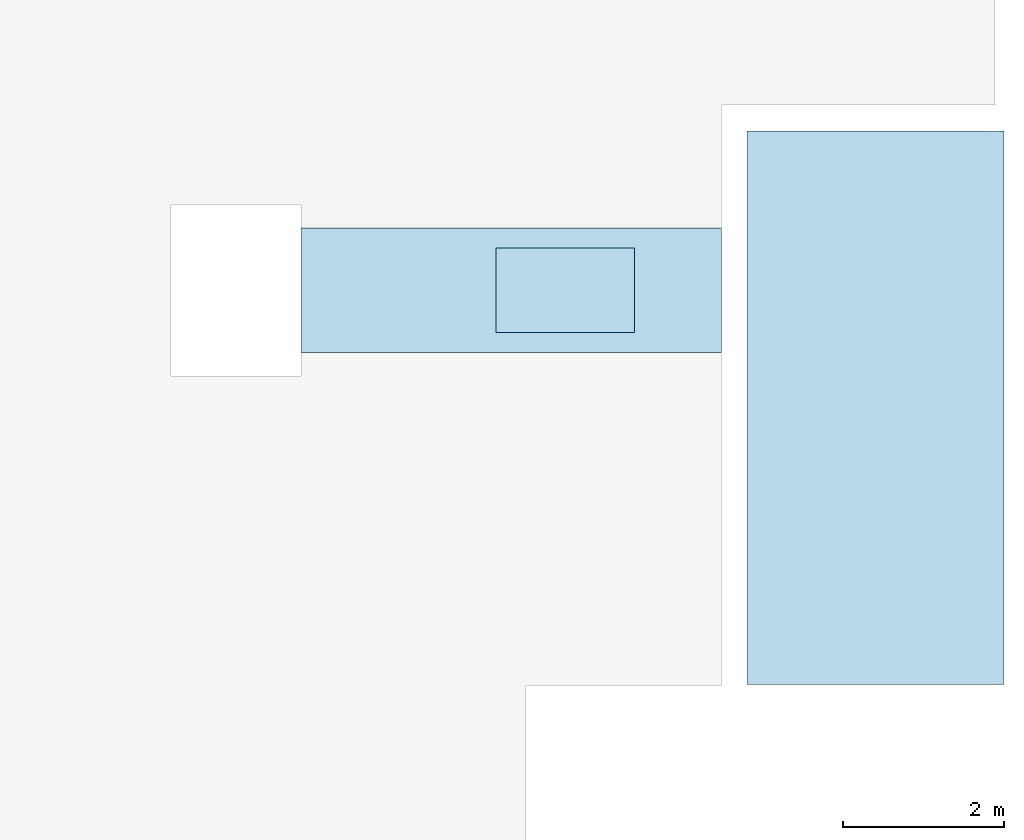
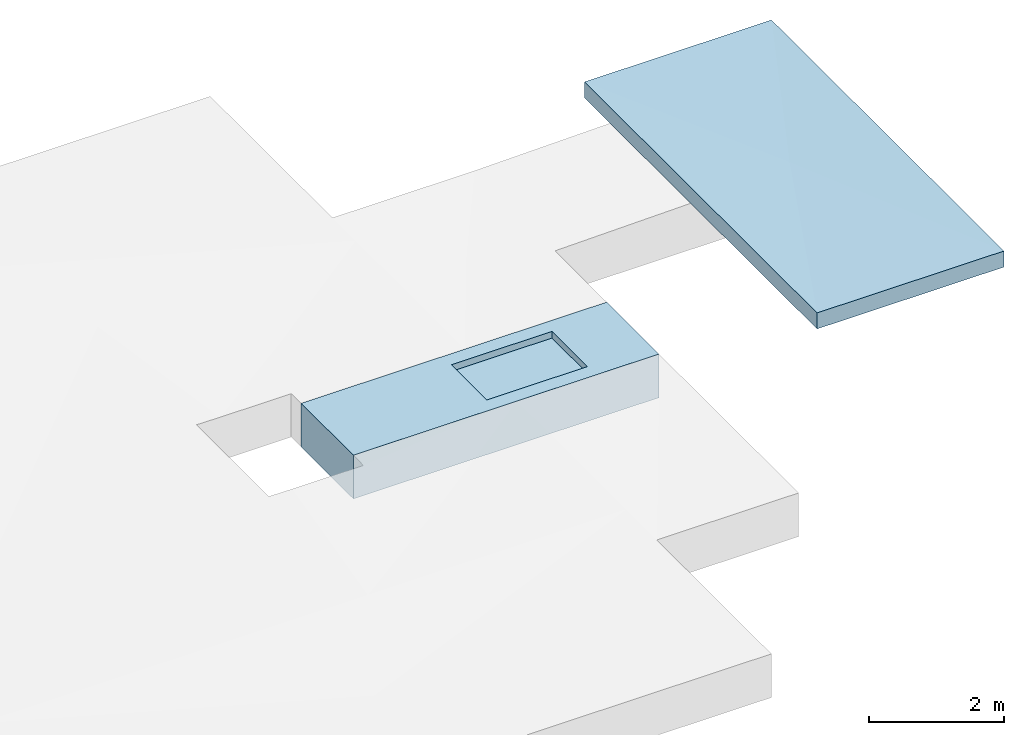
# One storey, part 1 of 2: 2 slabs.
"""IFC2X3 building model written with IfcOpenShell, lengths in millimetres."""

from ifc_helpers import new_model, entity, si_unit, converted_unit, derived_unit, direction, frame, frame_2d, origin, place, context, subcontext, project, spatial, polyline, rectangle, extrude, boolean, clip, bounded_halfspace, faceted_brep, material, material_list, layer, layer_set, layer_usage, type_object, element, save


model = new_model("IFC2X3")

# Units and contexts
model_context = context("Model", 3, precision=0.01, world=origin(), true_north=direction((6.12303176911189e-17, 1.0)))
body_context = subcontext(model_context, "Body", "Model", "MODEL_VIEW")
ifc_project = project(units=[si_unit("LENGTHUNIT", "METRE", prefix="MILLI"), si_unit("AREAUNIT", "SQUARE_METRE"), si_unit("VOLUMEUNIT", "CUBIC_METRE"), converted_unit("PLANEANGLEUNIT", "DEGREE", entity("IfcRatioMeasure", 0.0174532925199433), si_unit("PLANEANGLEUNIT", "RADIAN"), dimensions=[0, 0, 0, 0, 0, 0, 0]), si_unit("MASSUNIT", "GRAM", prefix="KILO"), derived_unit("MASSDENSITYUNIT", [(si_unit("MASSUNIT", "GRAM", prefix="KILO"), 1), (si_unit("LENGTHUNIT", "METRE"), -3)]), si_unit("TIMEUNIT", "SECOND"), si_unit("FREQUENCYUNIT", "HERTZ"), si_unit("THERMODYNAMICTEMPERATUREUNIT", "DEGREE_CELSIUS"), derived_unit("THERMALTRANSMITTANCEUNIT", [(si_unit("MASSUNIT", "GRAM", prefix="KILO"), 1), (si_unit("THERMODYNAMICTEMPERATUREUNIT", "KELVIN"), -1), (si_unit("TIMEUNIT", "SECOND"), -3)]), derived_unit("VOLUMETRICFLOWRATEUNIT", [(si_unit("LENGTHUNIT", "METRE"), 3), (si_unit("TIMEUNIT", "SECOND"), -1)]), si_unit("ELECTRICCURRENTUNIT", "AMPERE"), si_unit("ELECTRICVOLTAGEUNIT", "VOLT"), si_unit("POWERUNIT", "WATT"), si_unit("FORCEUNIT", "NEWTON", prefix="KILO"), si_unit("ILLUMINANCEUNIT", "LUX"), si_unit("LUMINOUSFLUXUNIT", "LUMEN"), si_unit("LUMINOUSINTENSITYUNIT", "CANDELA"), derived_unit("USERDEFINED", [(si_unit("MASSUNIT", "GRAM", prefix="KILO"), -1), (si_unit("LENGTHUNIT", "METRE"), -2), (si_unit("TIMEUNIT", "SECOND"), 3), (si_unit("LUMINOUSFLUXUNIT", "LUMEN"), 1)]), derived_unit("LINEARVELOCITYUNIT", [(si_unit("LENGTHUNIT", "METRE"), 1), (si_unit("TIMEUNIT", "SECOND"), -1)]), si_unit("PRESSUREUNIT", "PASCAL"), derived_unit("USERDEFINED", [(si_unit("LENGTHUNIT", "METRE"), -2), (si_unit("MASSUNIT", "GRAM", prefix="KILO"), 1), (si_unit("TIMEUNIT", "SECOND"), -2)])], contexts=[model_context])

# Site, building, storey
site_placement = place(None, origin())
site = spatial("IfcSite", under=ifc_project, at=site_placement, CompositionType="ELEMENT")
building_placement = place(site_placement, origin())
building = spatial("IfcBuilding", under=site, at=building_placement, CompositionType="ELEMENT")
storey_placement = place(building_placement, frame((0.0, 0.0, 16000.0)))
storey = spatial("IfcBuildingStorey", under=building, at=storey_placement, Name="04 Roof", CompositionType="ELEMENT", Elevation=16000.0)

# Slabs
ifc_material_1 = material(Name="01")
ifc_layer_1 = layer(ifc_material_1, 450.0)
ifc_material_2 = material(Name="04_XPS PLUS 30 SF")
ifc_layer_2 = layer(ifc_material_2, 200.0)
ifc_material_3 = material(Name="06_ APP")
ifc_layer_3 = layer(ifc_material_3, 10.0)
ifc_material_4 = material(Name="02_Beton, C40/55")
ifc_layer_4 = layer(ifc_material_4, 130.0)
ifc_layer_set = layer_set([ifc_layer_1, ifc_layer_2, ifc_layer_3, ifc_layer_4], Name="Floor")
ifc_layer_usage = layer_usage(ifc_layer_set, "AXIS3", "POSITIVE", 0.0)
slab_type_1 = type_object("IfcSlabType", Name="Floor", PredefinedType="FLOOR", material=ifc_layer_set)
slab_1_placement = place(storey_placement, origin())
element("IfcSlab", 1, at=slab_1_placement, inside=storey, type_object=slab_type_1, material=ifc_layer_usage, Name="Floor", ObjectType="Floor", PredefinedType="FLOOR", context=body_context, shape_type="CSG", body=[
    boolean("DIFFERENCE", clip(extrude(rectangle(XDim=1550.0, YDim=5230.0, at=frame_2d((4.32009983342141e-12, 0.0), x_axis=(1.0, 0.0))), frame((28328.4900708518, -68831.2395851399, 650.0), z_axis=(0.0, 0.0, -1.0), x_axis=(0.0, 1.0, 0.0)), (0.0, 0.0, 1.0), 790.0), bounded_halfspace(frame((29862.4563817403, -68306.2395851399, 530.0), z_axis=(0.0, 0.0, 1.0), x_axis=(0.0, -1.0, 0.0)), False, frame((28328.4900708518, -68831.2395851399, 650.0), z_axis=(0.0, 0.0, -1.0), x_axis=(0.0, 1.0, 0.0)), polyline([(-525.0, 1533.96631088847), (525.0, 1533.96631088847), (525.0, -186.478368556356), (-525.0, -186.478368556356), (-525.0, 1533.96631088847)]))), extrude(rectangle(XDim=1050.0, YDim=1720.44467944483, at=frame_2d((0.0, 2.1600499167107e-12), x_axis=(1.0, 0.0))), frame((29002.2340420179, -68831.2395851399, 530.0), z_axis=(0.0, 0.0, 1.0), x_axis=(0.0, 1.0, 0.0)), (0.0, 0.0, 1.0), 119.999999999999)),
])
ifc_material_list = material_list([ifc_material_1, ifc_material_2, ifc_material_3, ifc_material_4])
slab_type_2 = type_object("IfcSlabType", Name="Floor", PredefinedType="FLOOR")
slab_2_placement = place(storey_placement, origin())
element("IfcSlab", 2, at=slab_2_placement, inside=storey, type_object=slab_type_2, material=ifc_material_list, Name="Floor", ObjectType="Floor", PredefinedType="FLOOR", context=body_context, shape_type="Brep", body=[
    faceted_brep([(31263.4900708518, -73740.8241905963, 3500.0), (31263.4900708518, -66845.8241905964, 3500.0), (34463.4900708518, -66845.8241905964, 3500.0), (34463.4900708518, -73740.8241905964, 3500.0), (31263.4900708518, -73740.8241905963, 3790.0), (31263.4900708518, -66845.8241905964, 3790.0), (34463.4900708518, -66845.8241905964, 3790.0), (34463.4900708518, -73740.8241905964, 3790.0), (32922.2912938176, -70050.2451780942, 3700.0)], [[[0, 1, 2, 3]], [[1, 0, 4, 5]], [[2, 1, 5, 6]], [[3, 2, 6, 7]], [[0, 3, 7, 4]], [[7, 6, 8]], [[5, 4, 8]], [[7, 8, 4]], [[6, 5, 8]]]),
])

save(model, "model.ifc")
